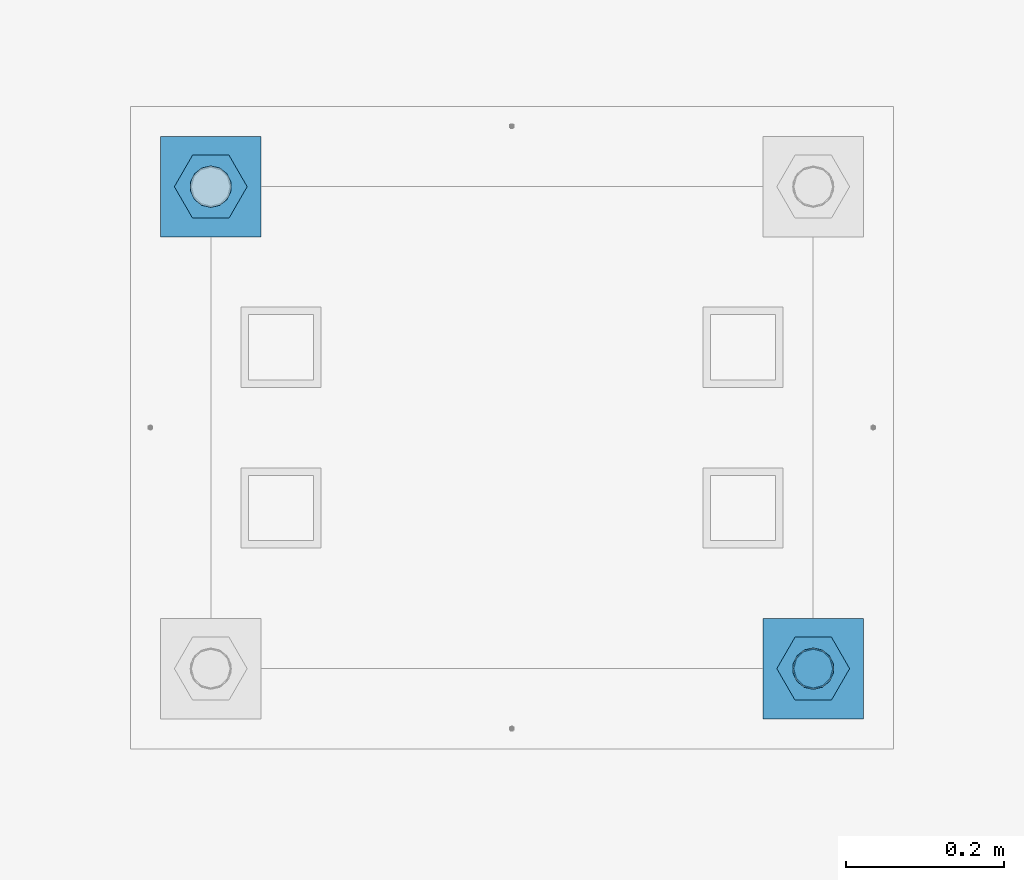
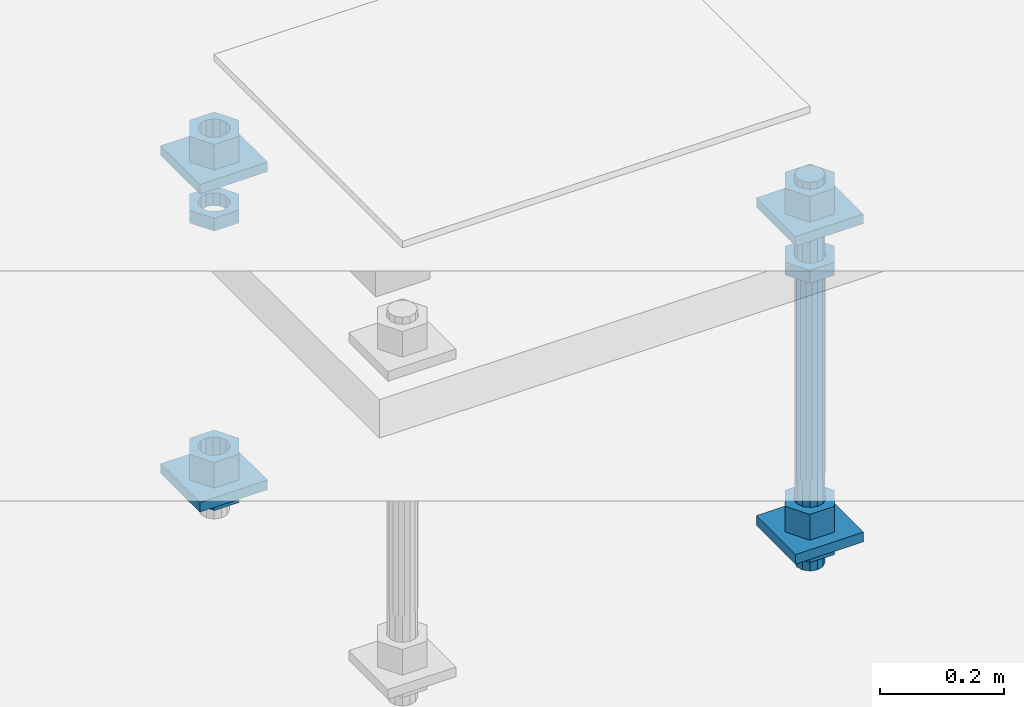
# One storey, part 2580 of 3843: 13 beams, 1 element without a shape of its own.
"""IFC2X3 building model written with IfcOpenShell, lengths in millimetres."""

from ifc_helpers import new_model, si_unit, frame, origin_with_axes, place, context, subcontext, project, spatial, faceted_brep, material, type_object, element, aggregate, save


model = new_model("IFC2X3")

# Units and contexts
model_context = context("Model", 3, precision=1e-05, world=origin_with_axes())
body_context = subcontext(model_context, "Body", "Model", "MODEL_VIEW")
ifc_project = project(units=[si_unit("LENGTHUNIT", "METRE", prefix="MILLI"), si_unit("AREAUNIT", "SQUARE_METRE"), si_unit("VOLUMEUNIT", "CUBIC_METRE"), si_unit("MASSUNIT", "GRAM", prefix="KILO"), si_unit("TIMEUNIT", "SECOND"), si_unit("PLANEANGLEUNIT", "RADIAN"), si_unit("SOLIDANGLEUNIT", "STERADIAN"), si_unit("THERMODYNAMICTEMPERATUREUNIT", "DEGREE_CELSIUS"), si_unit("LUMINOUSINTENSITYUNIT", "LUMEN")], contexts=[model_context])

# Site, building, storey
site_placement = place(None, origin_with_axes())
site = spatial("IfcSite", under=ifc_project, at=site_placement, CompositionType="ELEMENT")
building_placement = place(site_placement, origin_with_axes())
building = spatial("IfcBuilding", under=site, at=building_placement, Name="Undefined", CompositionType="ELEMENT")
storey_placement = place(building_placement, origin_with_axes())
storey = spatial("IfcBuildingStorey", under=building, at=storey_placement, Name="Undefined", CompositionType="ELEMENT", Elevation=0.0)

# Assembly, beams
assembly_placement = place(storey_placement, origin_with_axes())
assembly = element("IfcElementAssembly", 1, at=assembly_placement, inside=storey, Name="TEMPLATE", AssemblyPlace="NOTDEFINED", PredefinedType="RIGID_FRAME")
ifc_material_1 = material(Name="STEEL/A572-50")
beam_type_1 = type_object("IfcBeamType", PredefinedType="NOTDEFINED")
beam_1_placement = place(assembly_placement, frame((105537.0, 14401.8000015259, 29873.575), z_axis=(1.0, 0.0, 0.0), x_axis=(0.0, 1.0, 0.0)))
beam_1 = element("IfcBeam", 2, at=beam_1_placement, type_object=beam_type_1, material=ifc_material_1, Name="WASHER_PLATE", context=body_context, shape_type="Brep", body=[
    faceted_brep([(0.0, 9.52500000000146, -63.5), (0.0, 9.52500000000146, 63.5), (127.0, 9.52500000000146, 63.5), (127.0, 9.52500000000146, -63.5), (0.0, -9.52500000000146, 63.5), (127.0, -9.52500000000146, 63.5), (0.0, -9.52500000000146, -63.5), (127.0, -9.52500000000146, -63.5)], [[[0, 1, 2, 3]], [[1, 4, 5, 2]], [[4, 6, 7, 5]], [[6, 0, 3, 7]], [[5, 7, 3, 2]], [[6, 4, 1, 0]]]),
])
beam_2_placement = place(assembly_placement, frame((104775.0, 15011.4000015259, 29873.575), z_axis=(1.0, 0.0, 0.0), x_axis=(0.0, 1.0, 0.0)))
beam_2 = element("IfcBeam", 3, at=beam_2_placement, type_object=beam_type_1, material=ifc_material_1, Name="WASHER_PLATE", context=body_context, shape_type="Brep", body=[
    faceted_brep([(0.0, 9.52500000000146, -63.5), (0.0, 9.52500000000146, 63.5), (127.0, 9.52500000000146, 63.5), (127.0, 9.52500000000146, -63.5), (0.0, -9.52500000000146, 63.5), (127.0, -9.52500000000146, 63.5), (0.0, -9.52500000000146, -63.5), (127.0, -9.52500000000146, -63.5)], [[[0, 1, 2, 3]], [[1, 4, 5, 2]], [[4, 6, 7, 5]], [[6, 0, 3, 7]], [[5, 7, 3, 2]], [[6, 4, 1, 0]]]),
])
beam_3_placement = place(assembly_placement, frame((105537.0, 14401.8000015259, 29244.925), z_axis=(1.0, 0.0, 0.0), x_axis=(0.0, 1.0, 0.0)))
beam_3 = element("IfcBeam", 4, at=beam_3_placement, type_object=beam_type_1, material=ifc_material_1, Name="WASHER_PLATE", context=body_context, shape_type="Brep", body=[
    faceted_brep([(0.0, 9.52500000000146, -63.5), (0.0, 9.52500000000146, 63.5), (127.0, 9.52500000000146, 63.5), (127.0, 9.52500000000146, -63.5), (0.0, -9.52500000000146, 63.5), (127.0, -9.52500000000146, 63.5), (0.0, -9.52500000000146, -63.5), (127.0, -9.52500000000146, -63.5)], [[[0, 1, 2, 3]], [[1, 4, 5, 2]], [[4, 6, 7, 5]], [[6, 0, 3, 7]], [[5, 7, 3, 2]], [[6, 4, 1, 0]]]),
])
beam_4_placement = place(assembly_placement, frame((104775.0, 15011.4000015259, 29244.925), z_axis=(1.0, 0.0, 0.0), x_axis=(0.0, 1.0, 0.0)))
beam_4 = element("IfcBeam", 5, at=beam_4_placement, type_object=beam_type_1, material=ifc_material_1, Name="WASHER_PLATE", context=body_context, shape_type="Brep", body=[
    faceted_brep([(0.0, 9.52500000000146, -63.5), (0.0, 9.52500000000146, 63.5), (127.0, 9.52500000000146, 63.5), (127.0, 9.52500000000146, -63.5), (0.0, -9.52500000000146, 63.5), (127.0, -9.52500000000146, 63.5), (0.0, -9.52500000000146, -63.5), (127.0, -9.52500000000146, -63.5)], [[[0, 1, 2, 3]], [[1, 4, 5, 2]], [[4, 6, 7, 5]], [[6, 0, 3, 7]], [[5, 7, 3, 2]], [[6, 4, 1, 0]]]),
])
ifc_material_2 = material(Name="STEEL/A36")
beam_type_2 = type_object("IfcBeamType", Name="2_HALF_NUT", PredefinedType="NOTDEFINED")
beam_5_placement = place(assembly_placement, frame((105537.0, 14465.3000015259, 29787.85), z_axis=(0.0, 1.0, 0.0), x_axis=(0.0, 0.0, -1.0)))
beam_5 = element("IfcBeam", 6, at=beam_5_placement, type_object=beam_type_2, material=ifc_material_2, Name="NUT", ObjectType="2_HALF_NUT", context=body_context, shape_type="Brep", body=[
    faceted_brep([(0.0, -46.0369987487793, 0.0), (0.0, -23.0184993743896, -39.869213104248), (25.4000000000015, -23.0184993743896, -39.869213104248), (25.4000000000015, -46.0369987487793, 0.0), (0.0, 23.0184993743896, -39.869213104248), (25.4000000000015, 23.0184993743896, -39.869213104248), (0.0, 46.0369987487793, 0.0), (25.4000000000015, 46.0369987487793, 0.0), (0.0, 23.0184993743896, 39.869213104248), (25.4000000000015, 23.0184993743896, 39.869213104248), (0.0, -23.0184993743896, 39.869213104248), (25.4000000000015, -23.0184993743896, 39.869213104248), (0.0, 0.0, 26.1940002441406), (0.0, 11.3650617044477, 23.5999013092805), (25.4000000000015, 11.3650617044477, 23.5999013092805), (25.4000000000015, 0.0, 26.1940002441406), (0.0, 20.4791109456419, 16.3316083006721), (25.4000000000015, 20.4791109456419, 16.3316083006721), (0.0, 25.5370200498292, 5.82867859874386), (25.4000000000015, 25.5370200498292, 5.82867859874386), (0.0, 25.5370200498292, -5.82867859874386), (25.4000000000015, 25.5370200498292, -5.82867859874386), (0.0, 20.4791109456419, -16.3316083006721), (25.4000000000015, 20.4791109456419, -16.3316083006721), (0.0, 11.3650617044477, -23.5999013092805), (25.4000000000015, 11.3650617044477, -23.5999013092805), (0.0, 0.0, -26.1940002441406), (25.4000000000015, 0.0, -26.1940002441406), (0.0, -11.3650617044477, -23.5999013092805), (25.4000000000015, -11.3650617044477, -23.5999013092805), (0.0, -20.4791109456419, -16.3316083006721), (25.4000000000015, -20.4791109456419, -16.3316083006721), (0.0, -25.5370200498292, -5.82867859874386), (25.4000000000015, -25.5370200498292, -5.82867859874386), (0.0, -25.5370200498292, 5.82867859874386), (25.4000000000015, -25.5370200498292, 5.82867859874386), (0.0, -20.4791109456419, 16.3316083006721), (25.4000000000015, -20.4791109456419, 16.3316083006721), (0.0, -11.3650617044477, 23.5999013092805), (25.4000000000015, -11.3650617044477, 23.5999013092805)], [[[0, 1, 2, 3]], [[1, 4, 5, 2]], [[4, 6, 7, 5]], [[6, 8, 9, 7]], [[8, 10, 11, 9]], [[10, 0, 3, 11]], [[12, 13, 14, 15]], [[13, 16, 17, 14]], [[16, 18, 19, 17]], [[18, 20, 21, 19]], [[20, 22, 23, 21]], [[22, 24, 25, 23]], [[24, 26, 27, 25]], [[26, 28, 29, 27]], [[28, 30, 31, 29]], [[30, 32, 33, 31]], [[32, 34, 35, 33]], [[34, 36, 37, 35]], [[36, 38, 39, 37]], [[38, 12, 15, 39]], [[5, 7, 9, 11, 3, 2], [17, 19, 21, 23, 25, 27, 29, 31, 33, 35, 37, 39, 15, 14]], [[10, 8, 6, 4, 1, 0], [38, 36, 34, 32, 30, 28, 26, 24, 22, 20, 18, 16, 13, 12]]]),
])
beam_6_placement = place(assembly_placement, frame((105537.0, 14465.3000015259, 29235.4), z_axis=(0.0, 1.0, 0.0), x_axis=(0.0, 0.0, -1.0)))
beam_6 = element("IfcBeam", 7, at=beam_6_placement, type_object=beam_type_2, material=ifc_material_2, Name="NUT", ObjectType="2_HALF_NUT", context=body_context, shape_type="Brep", body=[
    faceted_brep([(0.0, -46.0369987487793, 0.0), (0.0, -23.0184993743896, -39.869213104248), (25.4000000000015, -23.0184993743896, -39.869213104248), (25.4000000000015, -46.0369987487793, 0.0), (0.0, 23.0184993743896, -39.869213104248), (25.4000000000015, 23.0184993743896, -39.869213104248), (0.0, 46.0369987487793, 0.0), (25.4000000000015, 46.0369987487793, 0.0), (0.0, 23.0184993743896, 39.869213104248), (25.4000000000015, 23.0184993743896, 39.869213104248), (0.0, -23.0184993743896, 39.869213104248), (25.4000000000015, -23.0184993743896, 39.869213104248), (0.0, 0.0, 26.1940002441406), (0.0, 11.3650617044477, 23.5999013092805), (25.4000000000015, 11.3650617044477, 23.5999013092805), (25.4000000000015, 0.0, 26.1940002441406), (0.0, 20.4791109456419, 16.3316083006721), (25.4000000000015, 20.4791109456419, 16.3316083006721), (0.0, 25.5370200498292, 5.82867859874386), (25.4000000000015, 25.5370200498292, 5.82867859874386), (0.0, 25.5370200498292, -5.82867859874386), (25.4000000000015, 25.5370200498292, -5.82867859874386), (0.0, 20.4791109456419, -16.3316083006721), (25.4000000000015, 20.4791109456419, -16.3316083006721), (0.0, 11.3650617044477, -23.5999013092805), (25.4000000000015, 11.3650617044477, -23.5999013092805), (0.0, 0.0, -26.1940002441406), (25.4000000000015, 0.0, -26.1940002441406), (0.0, -11.3650617044477, -23.5999013092805), (25.4000000000015, -11.3650617044477, -23.5999013092805), (0.0, -20.4791109456419, -16.3316083006721), (25.4000000000015, -20.4791109456419, -16.3316083006721), (0.0, -25.5370200498292, -5.82867859874386), (25.4000000000015, -25.5370200498292, -5.82867859874386), (0.0, -25.5370200498292, 5.82867859874386), (25.4000000000015, -25.5370200498292, 5.82867859874386), (0.0, -20.4791109456419, 16.3316083006721), (25.4000000000015, -20.4791109456419, 16.3316083006721), (0.0, -11.3650617044477, 23.5999013092805), (25.4000000000015, -11.3650617044477, 23.5999013092805)], [[[0, 1, 2, 3]], [[1, 4, 5, 2]], [[4, 6, 7, 5]], [[6, 8, 9, 7]], [[8, 10, 11, 9]], [[10, 0, 3, 11]], [[12, 13, 14, 15]], [[13, 16, 17, 14]], [[16, 18, 19, 17]], [[18, 20, 21, 19]], [[20, 22, 23, 21]], [[22, 24, 25, 23]], [[24, 26, 27, 25]], [[26, 28, 29, 27]], [[28, 30, 31, 29]], [[30, 32, 33, 31]], [[32, 34, 35, 33]], [[34, 36, 37, 35]], [[36, 38, 39, 37]], [[38, 12, 15, 39]], [[5, 7, 9, 11, 3, 2], [17, 19, 21, 23, 25, 27, 29, 31, 33, 35, 37, 39, 15, 14]], [[10, 8, 6, 4, 1, 0], [38, 36, 34, 32, 30, 28, 26, 24, 22, 20, 18, 16, 13, 12]]]),
])
beam_7_placement = place(assembly_placement, frame((104775.0, 15074.9000015259, 29787.85), z_axis=(0.0, 1.0, 0.0), x_axis=(0.0, 0.0, -1.0)))
beam_7 = element("IfcBeam", 8, at=beam_7_placement, type_object=beam_type_2, material=ifc_material_2, Name="NUT", ObjectType="2_HALF_NUT", context=body_context, shape_type="Brep", body=[
    faceted_brep([(0.0, -46.0369987487793, 0.0), (0.0, -23.0184993743896, -39.869213104248), (25.4000000000015, -23.0184993743896, -39.869213104248), (25.4000000000015, -46.0369987487793, 0.0), (0.0, 23.0184993743896, -39.869213104248), (25.4000000000015, 23.0184993743896, -39.869213104248), (0.0, 46.0369987487793, 0.0), (25.4000000000015, 46.0369987487793, 0.0), (0.0, 23.0184993743896, 39.869213104248), (25.4000000000015, 23.0184993743896, 39.869213104248), (0.0, -23.0184993743896, 39.869213104248), (25.4000000000015, -23.0184993743896, 39.869213104248), (0.0, 0.0, 26.1940002441406), (0.0, 11.3650617044477, 23.5999013092805), (25.4000000000015, 11.3650617044477, 23.5999013092805), (25.4000000000015, 0.0, 26.1940002441406), (0.0, 20.4791109456419, 16.3316083006721), (25.4000000000015, 20.4791109456419, 16.3316083006721), (0.0, 25.5370200498292, 5.82867859874386), (25.4000000000015, 25.5370200498292, 5.82867859874386), (0.0, 25.5370200498292, -5.82867859874386), (25.4000000000015, 25.5370200498292, -5.82867859874386), (0.0, 20.4791109456419, -16.3316083006721), (25.4000000000015, 20.4791109456419, -16.3316083006721), (0.0, 11.3650617044477, -23.5999013092805), (25.4000000000015, 11.3650617044477, -23.5999013092805), (0.0, 0.0, -26.1940002441406), (25.4000000000015, 0.0, -26.1940002441406), (0.0, -11.3650617044477, -23.5999013092805), (25.4000000000015, -11.3650617044477, -23.5999013092805), (0.0, -20.4791109456419, -16.3316083006721), (25.4000000000015, -20.4791109456419, -16.3316083006721), (0.0, -25.5370200498292, -5.82867859874386), (25.4000000000015, -25.5370200498292, -5.82867859874386), (0.0, -25.5370200498292, 5.82867859874386), (25.4000000000015, -25.5370200498292, 5.82867859874386), (0.0, -20.4791109456419, 16.3316083006721), (25.4000000000015, -20.4791109456419, 16.3316083006721), (0.0, -11.3650617044477, 23.5999013092805), (25.4000000000015, -11.3650617044477, 23.5999013092805)], [[[0, 1, 2, 3]], [[1, 4, 5, 2]], [[4, 6, 7, 5]], [[6, 8, 9, 7]], [[8, 10, 11, 9]], [[10, 0, 3, 11]], [[12, 13, 14, 15]], [[13, 16, 17, 14]], [[16, 18, 19, 17]], [[18, 20, 21, 19]], [[20, 22, 23, 21]], [[22, 24, 25, 23]], [[24, 26, 27, 25]], [[26, 28, 29, 27]], [[28, 30, 31, 29]], [[30, 32, 33, 31]], [[32, 34, 35, 33]], [[34, 36, 37, 35]], [[36, 38, 39, 37]], [[38, 12, 15, 39]], [[5, 7, 9, 11, 3, 2], [17, 19, 21, 23, 25, 27, 29, 31, 33, 35, 37, 39, 15, 14]], [[10, 8, 6, 4, 1, 0], [38, 36, 34, 32, 30, 28, 26, 24, 22, 20, 18, 16, 13, 12]]]),
])
beam_8_placement = place(assembly_placement, frame((104775.0, 15074.9000015259, 29235.4), z_axis=(0.0, 1.0, 0.0), x_axis=(0.0, 0.0, -1.0)))
beam_8 = element("IfcBeam", 9, at=beam_8_placement, type_object=beam_type_2, material=ifc_material_2, Name="NUT", ObjectType="2_HALF_NUT", context=body_context, shape_type="Brep", body=[
    faceted_brep([(0.0, -46.0369987487793, 0.0), (0.0, -23.0184993743896, -39.869213104248), (25.4000000000015, -23.0184993743896, -39.869213104248), (25.4000000000015, -46.0369987487793, 0.0), (0.0, 23.0184993743896, -39.869213104248), (25.4000000000015, 23.0184993743896, -39.869213104248), (0.0, 46.0369987487793, 0.0), (25.4000000000015, 46.0369987487793, 0.0), (0.0, 23.0184993743896, 39.869213104248), (25.4000000000015, 23.0184993743896, 39.869213104248), (0.0, -23.0184993743896, 39.869213104248), (25.4000000000015, -23.0184993743896, 39.869213104248), (0.0, 0.0, 26.1940002441406), (0.0, 11.3650617044477, 23.5999013092805), (25.4000000000015, 11.3650617044477, 23.5999013092805), (25.4000000000015, 0.0, 26.1940002441406), (0.0, 20.4791109456419, 16.3316083006721), (25.4000000000015, 20.4791109456419, 16.3316083006721), (0.0, 25.5370200498292, 5.82867859874386), (25.4000000000015, 25.5370200498292, 5.82867859874386), (0.0, 25.5370200498292, -5.82867859874386), (25.4000000000015, 25.5370200498292, -5.82867859874386), (0.0, 20.4791109456419, -16.3316083006721), (25.4000000000015, 20.4791109456419, -16.3316083006721), (0.0, 11.3650617044477, -23.5999013092805), (25.4000000000015, 11.3650617044477, -23.5999013092805), (0.0, 0.0, -26.1940002441406), (25.4000000000015, 0.0, -26.1940002441406), (0.0, -11.3650617044477, -23.5999013092805), (25.4000000000015, -11.3650617044477, -23.5999013092805), (0.0, -20.4791109456419, -16.3316083006721), (25.4000000000015, -20.4791109456419, -16.3316083006721), (0.0, -25.5370200498292, -5.82867859874386), (25.4000000000015, -25.5370200498292, -5.82867859874386), (0.0, -25.5370200498292, 5.82867859874386), (25.4000000000015, -25.5370200498292, 5.82867859874386), (0.0, -20.4791109456419, 16.3316083006721), (25.4000000000015, -20.4791109456419, 16.3316083006721), (0.0, -11.3650617044477, 23.5999013092805), (25.4000000000015, -11.3650617044477, 23.5999013092805)], [[[0, 1, 2, 3]], [[1, 4, 5, 2]], [[4, 6, 7, 5]], [[6, 8, 9, 7]], [[8, 10, 11, 9]], [[10, 0, 3, 11]], [[12, 13, 14, 15]], [[13, 16, 17, 14]], [[16, 18, 19, 17]], [[18, 20, 21, 19]], [[20, 22, 23, 21]], [[22, 24, 25, 23]], [[24, 26, 27, 25]], [[26, 28, 29, 27]], [[28, 30, 31, 29]], [[30, 32, 33, 31]], [[32, 34, 35, 33]], [[34, 36, 37, 35]], [[36, 38, 39, 37]], [[38, 12, 15, 39]], [[5, 7, 9, 11, 3, 2], [17, 19, 21, 23, 25, 27, 29, 31, 33, 35, 37, 39, 15, 14]], [[10, 8, 6, 4, 1, 0], [38, 36, 34, 32, 30, 28, 26, 24, 22, 20, 18, 16, 13, 12]]]),
])
beam_type_3 = type_object("IfcBeamType", Name="2_HEAVY_HEX_NUT", PredefinedType="NOTDEFINED")
beam_9_placement = place(assembly_placement, frame((105537.0, 14465.3000015259, 29933.9), z_axis=(0.0, 1.0, 0.0), x_axis=(0.0, 0.0, -1.0)))
beam_9 = element("IfcBeam", 10, at=beam_9_placement, type_object=beam_type_3, material=ifc_material_2, Name="NUT", ObjectType="2_HEAVY_HEX_NUT", context=body_context, shape_type="Brep", body=[
    faceted_brep([(0.0, -46.0369987487793, 0.0), (0.0, -23.0184993743896, -39.869213104248), (50.7999999999993, -23.0184993743896, -39.869213104248), (50.7999999999993, -46.0369987487793, 0.0), (0.0, 23.0184993743896, -39.869213104248), (50.7999999999993, 23.0184993743896, -39.869213104248), (0.0, 46.0369987487793, 0.0), (50.7999999999993, 46.0369987487793, 0.0), (0.0, 23.0184993743896, 39.869213104248), (50.7999999999993, 23.0184993743896, 39.869213104248), (0.0, -23.0184993743896, 39.869213104248), (50.7999999999993, -23.0184993743896, 39.869213104248), (0.0, 0.0, 26.1940002441406), (0.0, 11.3650617044477, 23.5999013092805), (50.7999999999993, 11.3650617044477, 23.5999013092805), (50.7999999999993, 0.0, 26.1940002441406), (0.0, 20.4791109456419, 16.3316083006721), (50.7999999999993, 20.4791109456419, 16.3316083006721), (0.0, 25.5370200498292, 5.82867859874386), (50.7999999999993, 25.5370200498292, 5.82867859874386), (0.0, 25.5370200498292, -5.82867859874386), (50.7999999999993, 25.5370200498292, -5.82867859874386), (0.0, 20.4791109456419, -16.3316083006721), (50.7999999999993, 20.4791109456419, -16.3316083006721), (0.0, 11.3650617044477, -23.5999013092805), (50.7999999999993, 11.3650617044477, -23.5999013092805), (0.0, 0.0, -26.1940002441406), (50.7999999999993, 0.0, -26.1940002441406), (0.0, -11.3650617044477, -23.5999013092805), (50.7999999999993, -11.3650617044477, -23.5999013092805), (0.0, -20.4791109456419, -16.3316083006721), (50.7999999999993, -20.4791109456419, -16.3316083006721), (0.0, -25.5370200498292, -5.82867859874386), (50.7999999999993, -25.5370200498292, -5.82867859874386), (0.0, -25.5370200498292, 5.82867859874386), (50.7999999999993, -25.5370200498292, 5.82867859874386), (0.0, -20.4791109456419, 16.3316083006721), (50.7999999999993, -20.4791109456419, 16.3316083006721), (0.0, -11.3650617044477, 23.5999013092805), (50.7999999999993, -11.3650617044477, 23.5999013092805)], [[[0, 1, 2, 3]], [[1, 4, 5, 2]], [[4, 6, 7, 5]], [[6, 8, 9, 7]], [[8, 10, 11, 9]], [[10, 0, 3, 11]], [[12, 13, 14, 15]], [[13, 16, 17, 14]], [[16, 18, 19, 17]], [[18, 20, 21, 19]], [[20, 22, 23, 21]], [[22, 24, 25, 23]], [[24, 26, 27, 25]], [[26, 28, 29, 27]], [[28, 30, 31, 29]], [[30, 32, 33, 31]], [[32, 34, 35, 33]], [[34, 36, 37, 35]], [[36, 38, 39, 37]], [[38, 12, 15, 39]], [[5, 7, 9, 11, 3, 2], [17, 19, 21, 23, 25, 27, 29, 31, 33, 35, 37, 39, 15, 14]], [[10, 8, 6, 4, 1, 0], [38, 36, 34, 32, 30, 28, 26, 24, 22, 20, 18, 16, 13, 12]]]),
])
beam_10_placement = place(assembly_placement, frame((105537.0, 14465.3000015259, 29305.25), z_axis=(0.0, 1.0, 0.0), x_axis=(0.0, 0.0, -1.0)))
beam_10 = element("IfcBeam", 11, at=beam_10_placement, type_object=beam_type_3, material=ifc_material_2, Name="NUT", ObjectType="2_HEAVY_HEX_NUT", context=body_context, shape_type="Brep", body=[
    faceted_brep([(0.0, -46.0369987487793, 0.0), (0.0, -23.0184993743896, -39.869213104248), (50.7999999999993, -23.0184993743896, -39.869213104248), (50.7999999999993, -46.0369987487793, 0.0), (0.0, 23.0184993743896, -39.869213104248), (50.7999999999993, 23.0184993743896, -39.869213104248), (0.0, 46.0369987487793, 0.0), (50.7999999999993, 46.0369987487793, 0.0), (0.0, 23.0184993743896, 39.869213104248), (50.7999999999993, 23.0184993743896, 39.869213104248), (0.0, -23.0184993743896, 39.869213104248), (50.7999999999993, -23.0184993743896, 39.869213104248), (0.0, 0.0, 26.1940002441406), (0.0, 11.3650617044477, 23.5999013092805), (50.7999999999993, 11.3650617044477, 23.5999013092805), (50.7999999999993, 0.0, 26.1940002441406), (0.0, 20.4791109456419, 16.3316083006721), (50.7999999999993, 20.4791109456419, 16.3316083006721), (0.0, 25.5370200498292, 5.82867859874386), (50.7999999999993, 25.5370200498292, 5.82867859874386), (0.0, 25.5370200498292, -5.82867859874386), (50.7999999999993, 25.5370200498292, -5.82867859874386), (0.0, 20.4791109456419, -16.3316083006721), (50.7999999999993, 20.4791109456419, -16.3316083006721), (0.0, 11.3650617044477, -23.5999013092805), (50.7999999999993, 11.3650617044477, -23.5999013092805), (0.0, 0.0, -26.1940002441406), (50.7999999999993, 0.0, -26.1940002441406), (0.0, -11.3650617044477, -23.5999013092805), (50.7999999999993, -11.3650617044477, -23.5999013092805), (0.0, -20.4791109456419, -16.3316083006721), (50.7999999999993, -20.4791109456419, -16.3316083006721), (0.0, -25.5370200498292, -5.82867859874386), (50.7999999999993, -25.5370200498292, -5.82867859874386), (0.0, -25.5370200498292, 5.82867859874386), (50.7999999999993, -25.5370200498292, 5.82867859874386), (0.0, -20.4791109456419, 16.3316083006721), (50.7999999999993, -20.4791109456419, 16.3316083006721), (0.0, -11.3650617044477, 23.5999013092805), (50.7999999999993, -11.3650617044477, 23.5999013092805)], [[[0, 1, 2, 3]], [[1, 4, 5, 2]], [[4, 6, 7, 5]], [[6, 8, 9, 7]], [[8, 10, 11, 9]], [[10, 0, 3, 11]], [[12, 13, 14, 15]], [[13, 16, 17, 14]], [[16, 18, 19, 17]], [[18, 20, 21, 19]], [[20, 22, 23, 21]], [[22, 24, 25, 23]], [[24, 26, 27, 25]], [[26, 28, 29, 27]], [[28, 30, 31, 29]], [[30, 32, 33, 31]], [[32, 34, 35, 33]], [[34, 36, 37, 35]], [[36, 38, 39, 37]], [[38, 12, 15, 39]], [[5, 7, 9, 11, 3, 2], [17, 19, 21, 23, 25, 27, 29, 31, 33, 35, 37, 39, 15, 14]], [[10, 8, 6, 4, 1, 0], [38, 36, 34, 32, 30, 28, 26, 24, 22, 20, 18, 16, 13, 12]]]),
])
beam_11_placement = place(assembly_placement, frame((104775.0, 15074.9000015259, 29933.9), z_axis=(0.0, 1.0, 0.0), x_axis=(0.0, 0.0, -1.0)))
beam_11 = element("IfcBeam", 12, at=beam_11_placement, type_object=beam_type_3, material=ifc_material_2, Name="NUT", ObjectType="2_HEAVY_HEX_NUT", context=body_context, shape_type="Brep", body=[
    faceted_brep([(0.0, -46.0369987487793, 0.0), (0.0, -23.0184993743896, -39.869213104248), (50.7999999999993, -23.0184993743896, -39.869213104248), (50.7999999999993, -46.0369987487793, 0.0), (0.0, 23.0184993743896, -39.869213104248), (50.7999999999993, 23.0184993743896, -39.869213104248), (0.0, 46.0369987487793, 0.0), (50.7999999999993, 46.0369987487793, 0.0), (0.0, 23.0184993743896, 39.869213104248), (50.7999999999993, 23.0184993743896, 39.869213104248), (0.0, -23.0184993743896, 39.869213104248), (50.7999999999993, -23.0184993743896, 39.869213104248), (0.0, 0.0, 26.1940002441406), (0.0, 11.3650617044477, 23.5999013092805), (50.7999999999993, 11.3650617044477, 23.5999013092805), (50.7999999999993, 0.0, 26.1940002441406), (0.0, 20.4791109456419, 16.3316083006721), (50.7999999999993, 20.4791109456419, 16.3316083006721), (0.0, 25.5370200498292, 5.82867859874386), (50.7999999999993, 25.5370200498292, 5.82867859874386), (0.0, 25.5370200498292, -5.82867859874386), (50.7999999999993, 25.5370200498292, -5.82867859874386), (0.0, 20.4791109456419, -16.3316083006721), (50.7999999999993, 20.4791109456419, -16.3316083006721), (0.0, 11.3650617044477, -23.5999013092805), (50.7999999999993, 11.3650617044477, -23.5999013092805), (0.0, 0.0, -26.1940002441406), (50.7999999999993, 0.0, -26.1940002441406), (0.0, -11.3650617044477, -23.5999013092805), (50.7999999999993, -11.3650617044477, -23.5999013092805), (0.0, -20.4791109456419, -16.3316083006721), (50.7999999999993, -20.4791109456419, -16.3316083006721), (0.0, -25.5370200498292, -5.82867859874386), (50.7999999999993, -25.5370200498292, -5.82867859874386), (0.0, -25.5370200498292, 5.82867859874386), (50.7999999999993, -25.5370200498292, 5.82867859874386), (0.0, -20.4791109456419, 16.3316083006721), (50.7999999999993, -20.4791109456419, 16.3316083006721), (0.0, -11.3650617044477, 23.5999013092805), (50.7999999999993, -11.3650617044477, 23.5999013092805)], [[[0, 1, 2, 3]], [[1, 4, 5, 2]], [[4, 6, 7, 5]], [[6, 8, 9, 7]], [[8, 10, 11, 9]], [[10, 0, 3, 11]], [[12, 13, 14, 15]], [[13, 16, 17, 14]], [[16, 18, 19, 17]], [[18, 20, 21, 19]], [[20, 22, 23, 21]], [[22, 24, 25, 23]], [[24, 26, 27, 25]], [[26, 28, 29, 27]], [[28, 30, 31, 29]], [[30, 32, 33, 31]], [[32, 34, 35, 33]], [[34, 36, 37, 35]], [[36, 38, 39, 37]], [[38, 12, 15, 39]], [[5, 7, 9, 11, 3, 2], [17, 19, 21, 23, 25, 27, 29, 31, 33, 35, 37, 39, 15, 14]], [[10, 8, 6, 4, 1, 0], [38, 36, 34, 32, 30, 28, 26, 24, 22, 20, 18, 16, 13, 12]]]),
])
beam_12_placement = place(assembly_placement, frame((104775.0, 15074.9000015259, 29305.25), z_axis=(0.0, 1.0, 0.0), x_axis=(0.0, 0.0, -1.0)))
beam_12 = element("IfcBeam", 13, at=beam_12_placement, type_object=beam_type_3, material=ifc_material_2, Name="NUT", ObjectType="2_HEAVY_HEX_NUT", context=body_context, shape_type="Brep", body=[
    faceted_brep([(0.0, -46.0369987487793, 0.0), (0.0, -23.0184993743896, -39.869213104248), (50.7999999999993, -23.0184993743896, -39.869213104248), (50.7999999999993, -46.0369987487793, 0.0), (0.0, 23.0184993743896, -39.869213104248), (50.7999999999993, 23.0184993743896, -39.869213104248), (0.0, 46.0369987487793, 0.0), (50.7999999999993, 46.0369987487793, 0.0), (0.0, 23.0184993743896, 39.869213104248), (50.7999999999993, 23.0184993743896, 39.869213104248), (0.0, -23.0184993743896, 39.869213104248), (50.7999999999993, -23.0184993743896, 39.869213104248), (0.0, 0.0, 26.1940002441406), (0.0, 11.3650617044477, 23.5999013092805), (50.7999999999993, 11.3650617044477, 23.5999013092805), (50.7999999999993, 0.0, 26.1940002441406), (0.0, 20.4791109456419, 16.3316083006721), (50.7999999999993, 20.4791109456419, 16.3316083006721), (0.0, 25.5370200498292, 5.82867859874386), (50.7999999999993, 25.5370200498292, 5.82867859874386), (0.0, 25.5370200498292, -5.82867859874386), (50.7999999999993, 25.5370200498292, -5.82867859874386), (0.0, 20.4791109456419, -16.3316083006721), (50.7999999999993, 20.4791109456419, -16.3316083006721), (0.0, 11.3650617044477, -23.5999013092805), (50.7999999999993, 11.3650617044477, -23.5999013092805), (0.0, 0.0, -26.1940002441406), (50.7999999999993, 0.0, -26.1940002441406), (0.0, -11.3650617044477, -23.5999013092805), (50.7999999999993, -11.3650617044477, -23.5999013092805), (0.0, -20.4791109456419, -16.3316083006721), (50.7999999999993, -20.4791109456419, -16.3316083006721), (0.0, -25.5370200498292, -5.82867859874386), (50.7999999999993, -25.5370200498292, -5.82867859874386), (0.0, -25.5370200498292, 5.82867859874386), (50.7999999999993, -25.5370200498292, 5.82867859874386), (0.0, -20.4791109456419, 16.3316083006721), (50.7999999999993, -20.4791109456419, 16.3316083006721), (0.0, -11.3650617044477, 23.5999013092805), (50.7999999999993, -11.3650617044477, 23.5999013092805)], [[[0, 1, 2, 3]], [[1, 4, 5, 2]], [[4, 6, 7, 5]], [[6, 8, 9, 7]], [[8, 10, 11, 9]], [[10, 0, 3, 11]], [[12, 13, 14, 15]], [[13, 16, 17, 14]], [[16, 18, 19, 17]], [[18, 20, 21, 19]], [[20, 22, 23, 21]], [[22, 24, 25, 23]], [[24, 26, 27, 25]], [[26, 28, 29, 27]], [[28, 30, 31, 29]], [[30, 32, 33, 31]], [[32, 34, 35, 33]], [[34, 36, 37, 35]], [[36, 38, 39, 37]], [[38, 12, 15, 39]], [[5, 7, 9, 11, 3, 2], [17, 19, 21, 23, 25, 27, 29, 31, 33, 35, 37, 39, 15, 14]], [[10, 8, 6, 4, 1, 0], [38, 36, 34, 32, 30, 28, 26, 24, 22, 20, 18, 16, 13, 12]]]),
])
ifc_material_3 = material()
beam_type_4 = type_object("IfcBeamType", PredefinedType="NOTDEFINED")
beam_13_placement = place(assembly_placement, frame((105537.000001526, 14465.3, 29762.45), z_axis=(1.0, 0.0, 0.0), x_axis=(0.0, 0.0, -1.0)))
beam_13 = element("IfcBeam", 14, at=beam_13_placement, type_object=beam_type_4, material=ifc_material_3, Name="ANCHOR_ROD", context=body_context, shape_type="Brep", body=[
    faceted_brep([(0.0, -23.4665401257807, -9.72015918207035), (0.0, -17.9605122421344, -17.9605122421417), (406.399999999998, -17.9605122421344, -17.9605122421417), (406.399999999998, -23.4665401257807, -9.72015918207035), (0.0, -9.72015918207762, -23.466540125788), (406.399999999998, -9.72015918207762, -23.466540125788), (0.0, 0.0, -25.4000000000015), (406.399999999998, 0.0, -25.4000000000015), (0.0, 9.72015918207762, -23.466540125788), (406.399999999998, 9.72015918207762, -23.466540125788), (0.0, 17.9605122421344, -17.9605122421417), (406.399999999998, 17.9605122421344, -17.9605122421417), (0.0, 23.4665401257807, -9.72015918207035), (406.399999999998, 23.4665401257807, -9.72015918207035), (0.0, 25.3999996185303, 0.0), (406.399999999998, 25.3999999999942, 0.0), (0.0, 23.4665401257807, 9.72015918207035), (406.399999999998, 23.4665401257807, 9.72015918207035), (0.0, 17.9605122421344, 17.9605122421417), (406.399999999998, 17.9605122421344, 17.9605122421417), (0.0, 9.72015918207762, 23.466540125788), (406.399999999998, 9.72015918207762, 23.466540125788), (0.0, 0.0, 25.4000000000015), (406.399999999998, 0.0, 25.4000000000015), (0.0, -9.72015918207762, 23.466540125788), (406.399999999998, -9.72015918207762, 23.466540125788), (0.0, -17.9605122421344, 17.9605122421417), (406.399999999998, -17.9605122421344, 17.9605122421417), (0.0, -23.4665401257807, 9.72015918207035), (406.399999999998, -23.4665401257807, 9.72015918207035), (0.0, -25.3999996185303, 0.0), (406.399999999998, -25.3999999999942, 0.0), (584.200000000001, -12.2499999999854, -21.2176223927163), (584.200000000001, 1.45519152283669e-11, -24.5), (584.200000000001, 12.2500000000146, -21.2176223927163), (584.200000000001, 21.2176223927381, -12.25), (584.200000000001, 24.5000000000146, 0.0), (584.200000000001, 21.2176223927381, 12.25), (584.200000000001, 12.2500000000146, 21.2176223927163), (584.200000000001, 1.45519152283669e-11, 24.5), (584.200000000001, -12.2499999999854, 21.2176223927163), (584.200000000001, -21.217622392709, 12.25), (584.200000000001, -24.4999999999854, 0.0), (584.200000000001, -21.217622392709, -12.25), (406.399999999998, -24.4999999999854, 0.0), (406.399999999998, -21.217622392709, -12.25), (406.399999999998, -12.2499999999854, -21.2176223927163), (406.399999999998, 1.45519152283669e-11, -24.5), (406.399999999998, 12.2500000000146, -21.2176223927163), (406.399999999998, 21.2176223927381, -12.25), (406.399999999998, 24.5000000000146, 0.0), (406.399999999998, 21.2176223927381, 12.25), (406.399999999998, 12.2500000000146, 21.2176223927163), (406.399999999998, 1.45519152283669e-11, 24.5), (406.399999999998, -12.2499999999854, 21.2176223927163), (406.399999999998, -21.217622392709, 12.25), (0.0, 12.2500000000146, 21.2176223927163), (0.0, 1.45519152283669e-11, 24.5), (0.0, -12.2499999999854, 21.2176223927163), (0.0, -21.217622392709, 12.25), (0.0, -24.4999999999854, 0.0), (0.0, -21.217622392709, -12.25), (0.0, -12.2499999999854, -21.2176223927163), (0.0, 1.45519152283669e-11, -24.5), (0.0, 12.2500000000146, -21.2176223927163), (0.0, 21.2176223927381, -12.25), (0.0, 24.5000000000146, 0.0), (0.0, 21.2176223927381, 12.25), (-184.150000000001, -21.217622392709, 12.25), (-184.150000000001, -12.2499999999854, 21.2176223927163), (-184.150000000001, 1.45519152283669e-11, 24.5), (-184.150000000001, 12.2500000000146, 21.2176223927163), (-184.150000000001, 21.2176223927381, 12.25), (-184.150000000001, 24.5000000000146, 0.0), (-184.150000000001, 21.2176223927381, -12.25), (-184.150000000001, 12.2500000000146, -21.2176223927163), (-184.150000000001, 1.45519152283669e-11, -24.5), (-184.150000000001, -12.2499999999854, -21.2176223927163), (-184.150000000001, -21.217622392709, -12.25), (-184.150000000001, -24.4999999999854, 0.0)], [[[0, 1, 2, 3]], [[1, 4, 5, 2]], [[4, 6, 7, 5]], [[6, 8, 9, 7]], [[8, 10, 11, 9]], [[10, 12, 13, 11]], [[12, 14, 15, 13]], [[14, 16, 17, 15]], [[16, 18, 19, 17]], [[18, 20, 21, 19]], [[20, 22, 23, 21]], [[22, 24, 25, 23]], [[24, 26, 27, 25]], [[26, 28, 29, 27]], [[28, 30, 31, 29]], [[32, 33, 34, 35, 36, 37, 38, 39, 40, 41, 42, 43]], [[43, 42, 44, 45]], [[32, 43, 45, 46]], [[33, 32, 46, 47]], [[34, 33, 47, 48]], [[35, 34, 48, 49]], [[36, 35, 49, 50]], [[37, 36, 50, 51]], [[38, 37, 51, 52]], [[39, 38, 52, 53]], [[40, 39, 53, 54]], [[41, 40, 54, 55]], [[42, 41, 55, 44]], [[2, 5, 7, 9, 11, 13, 15, 17, 19, 21, 23, 25, 27, 29, 31, 3], [54, 53, 52, 51, 50, 49, 48, 47, 46, 45, 44, 55]], [[30, 0, 3, 31]], [[28, 26, 24, 22, 20, 18, 16, 14, 12, 10, 8, 6, 4, 1, 0, 30], [56, 57, 58, 59, 60, 61, 62, 63, 64, 65, 66, 67]], [[68, 69, 70, 71, 72, 73, 74, 75, 76, 77, 78, 79]], [[71, 70, 57, 56]], [[72, 71, 56, 67]], [[73, 72, 67, 66]], [[74, 73, 66, 65]], [[75, 74, 65, 64]], [[76, 75, 64, 63]], [[77, 76, 63, 62]], [[78, 77, 62, 61]], [[79, 78, 61, 60]], [[68, 79, 60, 59]], [[69, 68, 59, 58]], [[70, 69, 58, 57]]]),
])
aggregate(assembly, [beam_13, beam_1, beam_2, beam_5, beam_9, beam_10, beam_6, beam_3, beam_7, beam_11, beam_12, beam_8, beam_4])

save(model, "model.ifc")
